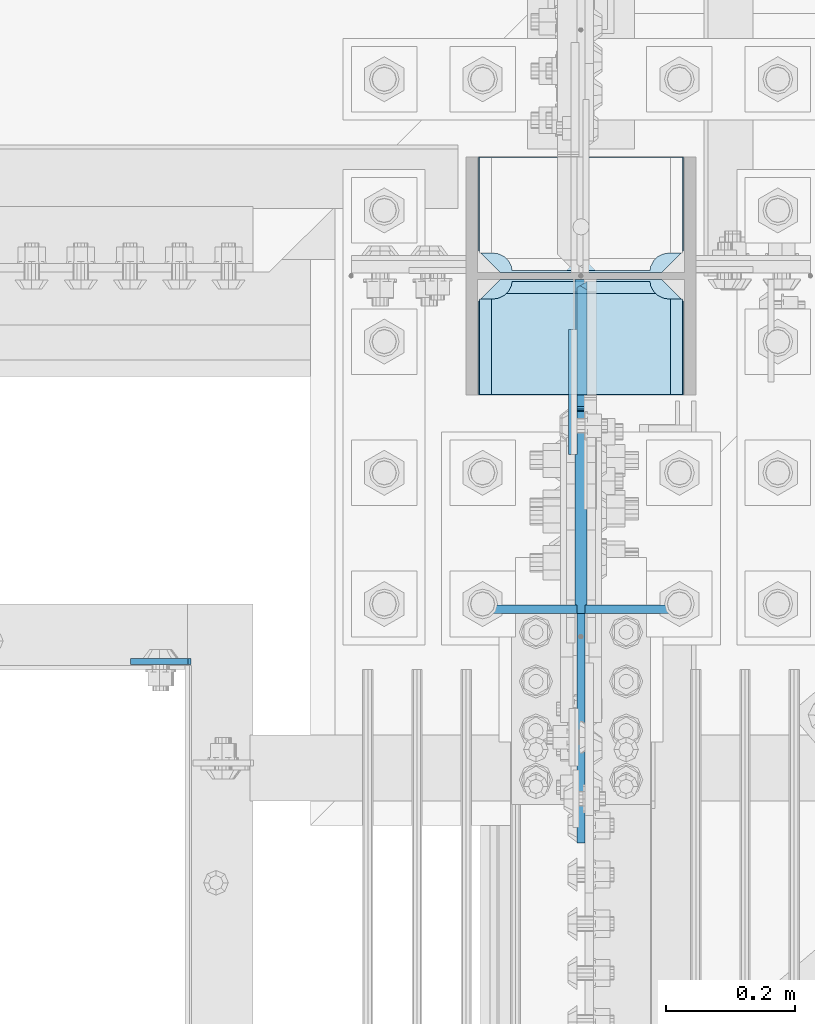
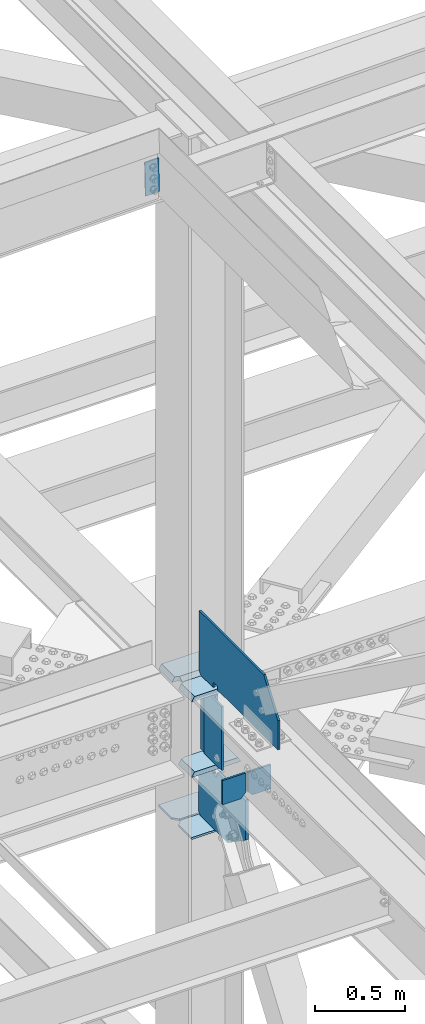
# One storey, part 3195 of 3843: 12 plates, 3 elements without a shape of their own.
"""IFC2X3 building model written with IfcOpenShell, lengths in millimetres."""

from ifc_helpers import new_model, si_unit, frame, origin_with_axes, place, context, subcontext, project, spatial, faceted_brep, material, type_object, element, aggregate, save


model = new_model("IFC2X3")

# Units and contexts
model_context = context("Model", 3, precision=1e-05, world=origin_with_axes())
body_context = subcontext(model_context, "Body", "Model", "MODEL_VIEW")
ifc_project = project(units=[si_unit("LENGTHUNIT", "METRE", prefix="MILLI"), si_unit("AREAUNIT", "SQUARE_METRE"), si_unit("VOLUMEUNIT", "CUBIC_METRE"), si_unit("MASSUNIT", "GRAM", prefix="KILO"), si_unit("TIMEUNIT", "SECOND"), si_unit("PLANEANGLEUNIT", "RADIAN"), si_unit("SOLIDANGLEUNIT", "STERADIAN"), si_unit("THERMODYNAMICTEMPERATUREUNIT", "DEGREE_CELSIUS"), si_unit("LUMINOUSINTENSITYUNIT", "LUMEN")], contexts=[model_context])

# Site, building, storey
site_placement = place(None, origin_with_axes())
site = spatial("IfcSite", under=ifc_project, at=site_placement, CompositionType="ELEMENT")
building_placement = place(site_placement, origin_with_axes())
building = spatial("IfcBuilding", under=site, at=building_placement, Name="Undefined", CompositionType="ELEMENT")
storey_placement = place(building_placement, origin_with_axes())
storey = spatial("IfcBuildingStorey", under=building, at=storey_placement, Name="Undefined", CompositionType="ELEMENT", Elevation=0.0)

# Assembly, plate
assembly_1_placement = place(storey_placement, origin_with_axes())
assembly_1 = element("IfcElementAssembly", 1, at=assembly_1_placement, inside=storey, Name="CHANNEL", AssemblyPlace="NOTDEFINED", PredefinedType="RIGID_FRAME")
ifc_material = material(Name="STEEL/A572-50")
plate_type_1 = type_object("IfcPlateType", PredefinedType="NOTDEFINED")
plate_1_placement = place(assembly_1_placement, frame((76404.0058949425, 25019.0000000661, 46534.1205115936), z_axis=(-0.999776270257024, 0.0, -0.0211520550054595), x_axis=(0.0211520550054438, 0.0, -0.999776270257025)))
plate_1 = element("IfcPlate", 2, at=plate_1_placement, type_object=plate_type_1, material=ifc_material, Name="PLATE", context=body_context, shape_type="Brep", body=[
    faceted_brep([(0.0, -4.76249999999709, 0.0), (0.0, -4.76249999999709, 88.9000015258789), (0.0, 4.76249999999709, 88.9000015258789), (0.0, 4.76249999999709, 0.0), (228.600006102781, -4.7625000004191, 88.9000015257589), (228.600006102781, 4.76249999954598, 88.9000015257443), (228.600006103079, -4.7625000004482, 7.27595761418343e-12), (228.600006103079, 4.76249999954598, -7.27595761418343e-12)], [[[0, 1, 2, 3]], [[1, 4, 5, 2]], [[4, 6, 7, 5]], [[6, 0, 3, 7]], [[5, 7, 3, 2]], [[6, 4, 1, 0]]]),
])
aggregate(assembly_1, [plate_1])

# Assembly, plates
assembly_2_placement = place(storey_placement, origin_with_axes())
assembly_2 = element("IfcElementAssembly", 3, at=assembly_2_placement, inside=storey, Name="BEAM", AssemblyPlace="NOTDEFINED", PredefinedType="RIGID_FRAME")
plate_type_2 = type_object("IfcPlateType", PredefinedType="NOTDEFINED")
plate_2_placement = place(assembly_2_placement, frame((77019.15, 25099.881157383, 42110.025), z_axis=(0.0, 0.0, -1.0), x_axis=(1.0, 0.0, 0.0)))
plate_2 = element("IfcPlate", 4, at=plate_2_placement, type_object=plate_type_2, material=ifc_material, Name="PLATE", context=body_context, shape_type="Brep", body=[
    faceted_brep([(0.0, -6.3499999046162, 0.0), (0.0, -6.35000000000582, 131.762499999997), (0.0, 6.35000000000582, 131.762499999997), (7.27595761418343e-12, 6.3499999046162, 0.0), (31.75, -6.35000000000582, 163.512499999997), (31.75, 6.35000000000582, 163.512499999997), (149.224999999991, -6.35000000000582, 163.512499999997), (149.224999999991, 6.35000000000582, 163.512499999997), (149.224999999991, -6.35000000000582, 0.0), (149.224999999991, 6.35000000000582, 0.0)], [[[0, 1, 2, 3]], [[1, 4, 5, 2]], [[4, 6, 7, 5]], [[6, 8, 9, 7]], [[8, 0, 3, 9]], [[5, 7, 9, 3, 2]], [[8, 6, 4, 1, 0]]]),
])
plate_3_placement = place(assembly_2_placement, frame((76857.225, 25099.881157383, 42110.025), z_axis=(0.0, 0.0, -1.0), x_axis=(1.0, 0.0, 0.0)))
plate_3 = element("IfcPlate", 5, at=plate_3_placement, type_object=plate_type_2, material=ifc_material, Name="PLATE", context=body_context, shape_type="Brep", body=[
    faceted_brep([(0.0, -6.3499999046162, 0.0), (0.0, -6.34999999999854, 163.512499999997), (0.0, 6.34999999999854, 163.512499999997), (7.27595761418343e-12, 6.3499999046162, 0.0), (117.474999999991, -6.34999999999854, 163.512499999997), (117.474999999991, 6.34999999999854, 163.512499999997), (149.224999999991, -6.34999999999854, 131.762499999997), (149.224999999991, 6.34999999999854, 131.762499999997), (149.224999999991, -6.35000000000582, 0.0), (149.224999999991, 6.35000000000582, 0.0)], [[[0, 1, 2, 3]], [[1, 4, 5, 2]], [[4, 6, 7, 5]], [[6, 8, 9, 7]], [[8, 0, 3, 9]], [[5, 7, 9, 3, 2]], [[8, 6, 4, 1, 0]]]),
])
aggregate(assembly_2, [plate_2, plate_3])

assembly_3_placement = place(storey_placement, origin_with_axes())
assembly_3 = element("IfcElementAssembly", 6, at=assembly_3_placement, inside=storey, Name="COLUMN", AssemblyPlace="NOTDEFINED", PredefinedType="RIGID_FRAME")
plate_type_3 = type_object("IfcPlateType", PredefinedType="NOTDEFINED")
plate_4_placement = place(assembly_3_placement, frame((77171.55, 25621.45625, 41513.3451620063), z_axis=(0.0, 1.0, 0.0), x_axis=(-1.0, 0.0, 0.0)))
plate_4 = element("IfcPlate", 7, at=plate_4_placement, type_object=plate_type_3, material=ifc_material, Name="CB_COL", context=body_context, shape_type="Brep", body=[
    faceted_brep([(0.0, -6.34999999999854, 33.3375015258789), (0.0, -6.34999999999854, 178.59375), (0.0, 6.34999999999854, 178.59375), (0.0, 6.34999999999854, 33.3375015258789), (317.499999999985, -6.34999999999854, 178.59375), (317.499999999985, 6.34999999999854, 178.59375), (317.499999999985, -6.34999999999854, 33.3375015258789), (317.499999999985, 6.34999999999854, 33.3375015258789), (284.162498474107, -6.34999999999854, 0.0), (284.162498474107, 6.34999999999854, 0.0), (33.3375015258789, -6.34999999999854, 0.0), (33.3375015258789, 6.34999999999854, 0.0)], [[[0, 1, 2, 3]], [[1, 4, 5, 2]], [[4, 6, 7, 5]], [[6, 8, 9, 7]], [[8, 10, 11, 9]], [[10, 0, 3, 11]], [[5, 7, 9, 11, 3, 2]], [[10, 8, 6, 4, 1, 0]]]),
])
plate_5_placement = place(assembly_3_placement, frame((77171.55, 25610.34375, 41513.3451620063), z_axis=(0.0, -1.0, 0.0), x_axis=(-1.0, 0.0, 0.0)))
plate_5 = element("IfcPlate", 8, at=plate_5_placement, type_object=plate_type_3, material=ifc_material, Name="CB_COL", context=body_context, shape_type="Brep", body=[
    faceted_brep([(0.0, -6.34999999999854, 33.3375015258789), (0.0, -6.34999999999854, 178.59375), (0.0, 6.34999999999854, 178.59375), (0.0, 6.34999999999854, 33.3375015258789), (317.499999999985, -6.34999999999854, 178.59375), (317.499999999985, 6.34999999999854, 178.59375), (317.499999999985, -6.34999999999854, 33.3375015258789), (317.499999999985, 6.34999999999854, 33.3375015258789), (284.162498474107, -6.34999999999854, 0.0), (284.162498474107, 6.34999999999854, 0.0), (33.3375015258789, -6.34999999999854, 0.0), (33.3375015258789, 6.34999999999854, 0.0)], [[[0, 1, 2, 3]], [[1, 4, 5, 2]], [[4, 6, 7, 5]], [[6, 8, 9, 7]], [[8, 10, 11, 9]], [[10, 0, 3, 11]], [[5, 7, 9, 11, 3, 2]], [[10, 8, 6, 4, 1, 0]]]),
])
plate_type_4 = type_object("IfcPlateType", PredefinedType="NOTDEFINED")
plate_6_placement = place(assembly_3_placement, frame((77012.8, 25093.531157383, 41925.875), z_axis=(0.0, 0.0, -1.0), x_axis=(0.0, 1.0, 0.0)))
plate_6 = element("IfcPlate", 9, at=plate_6_placement, type_object=plate_type_4, material=ifc_material, Name="CB", context=body_context, shape_type="Brep", body=[
    faceted_brep([(516.812592616985, -9.52499999999418, 387.129837993649), (516.812592616985, 9.52499999999418, 387.129837993649), (497.762592616986, 9.52499999999418, 406.179837993652), (497.762592616986, -9.52499999999418, 406.179837993652), (0.0, -9.52499999999418, 270.061563222225), (195.385083612466, -9.52499999999418, 406.179837993652), (195.385083612466, 9.52499999999418, 406.179837993652), (0.0, 9.52499999999418, 270.061563222225), (0.0, -9.52500000000146, 0.0), (0.0, 9.52500000000146, 0.0), (312.818842616984, 9.52499999999418, 0.0), (312.818842616984, -9.52499999999418, 0.0), (312.818842616984, 9.52499999999418, 25.4000001907334), (312.818842616984, -9.52499999999418, 25.4000001907334), (313.785572539571, 9.52499999999418, 30.2600797087798), (313.785572539571, -9.52499999999418, 30.2600797087798), (316.538586440049, 9.52499999999418, 34.3802561769335), (316.538586440049, -9.52499999999418, 34.3802561769335), (320.658762908202, 9.52499999999418, 37.1332700774074), (320.658762908202, -9.52499999999418, 37.1332700774074), (325.518842426249, 9.52499999999418, 38.0999999999985), (325.518842426249, -9.52499999999418, 38.0999999999985), (350.918842807718, 9.52499999999418, 38.0999999999985), (350.918842807718, -9.52499999999418, 38.0999999999985), (355.778922325764, 9.52499999999418, 37.1332700774074), (355.778922325764, -9.52499999999418, 37.1332700774074), (359.899098793918, 9.52499999999418, 34.3802561769335), (359.899098793918, -9.52499999999418, 34.3802561769335), (362.652112694395, 9.52499999999418, 30.2600797087798), (362.652112694395, -9.52499999999418, 30.2600797087798), (363.618842616983, 9.52499999999418, 25.4000001907334), (363.618842616983, -9.52499999999418, 25.4000001907334), (363.618842616983, 9.52499999999418, 0.0), (363.618842616983, -9.52499999999418, 0.0), (497.762593379925, 9.52499999999418, 0.0), (497.762593379925, -9.52499999999418, 0.0), (516.812592616985, -9.52499999999418, 19.0499992370605), (516.812592616985, 9.52499999999418, 19.0499992370605)], [[[0, 1, 2, 3]], [[4, 5, 6, 7]], [[8, 4, 7, 9]], [[8, 9, 10, 11]], [[11, 10, 12, 13]], [[13, 12, 14, 15]], [[15, 14, 16, 17]], [[17, 16, 18, 19]], [[19, 18, 20, 21]], [[21, 20, 22, 23]], [[23, 22, 24, 25]], [[25, 24, 26, 27]], [[27, 26, 28, 29]], [[29, 28, 30, 31]], [[31, 30, 32, 33]], [[34, 35, 33, 32]], [[36, 35, 34, 37]], [[5, 4, 8, 11, 13, 15, 17, 19, 21, 23, 25, 27, 29, 31, 33, 35, 36, 0, 3]], [[6, 5, 3, 2]], [[37, 34, 32, 30, 28, 26, 24, 22, 20, 18, 16, 14, 12, 10, 9, 7, 6, 2, 1]], [[36, 37, 1, 0]]]),
])
plate_type_5 = type_object("IfcPlateType", PredefinedType="NOTDEFINED")
plate_7_placement = place(assembly_3_placement, frame((77012.7999999709, 25610.3437500067, 42468.7999999896), z_axis=(0.0, -1.0, 0.0), x_axis=(0.0, 0.0, 1.0)))
plate_7 = element("IfcPlate", 10, at=plate_7_placement, type_object=plate_type_5, material=ifc_material, Name="PLATE", context=body_context, shape_type="Brep", body=[
    faceted_brep([(12.6999999999971, -6.35000000000582, 203.993750006706), (12.6999999999971, 6.35000000000582, 203.993750006706), (25.4000002011162, 6.35000000000582, 203.993750006706), (25.4000002011162, -6.35000000000582, 203.993750006706), (30.2600797191626, 6.35000000000582, 203.027020084119), (30.2600797191626, -6.35000000000582, 203.027020084119), (34.3802561873163, 6.35000000000582, 200.274006183641), (34.3802561873163, -6.35000000000582, 200.274006183641), (37.1332700877902, 6.35000000000582, 196.153829715488), (37.1332700877902, -6.35000000000582, 196.153829715488), (25.4000002011162, -6.35000000000582, 153.193750006707), (25.4000002011162, 6.35000000000582, 153.193750006707), (0.0, 6.35000000000582, 153.193750006707), (0.0, -6.35000000000582, 153.193750006707), (30.2600797191626, -6.35000000000582, 154.160479929295), (30.2600797191626, 6.35000000000582, 154.160479929295), (34.3802561873163, -6.35000000000582, 156.913493829772), (34.3802561873163, 6.35000000000582, 156.913493829772), (37.1332700877902, -6.35000000000582, 161.033670297926), (37.1332700877902, 6.35000000000582, 161.033670297926), (38.1000000103813, -6.35000000000582, 165.893749815972), (38.1000000103813, 6.35000000000582, 165.893749815972), (38.1000000103813, -6.35000000000582, 191.293750197441), (38.1000000103813, 6.35000000000582, 191.293750197441), (211.188134383417, -6.35000000000582, 872.381515932011), (211.188134383417, 6.35000000000582, 872.381515932011), (12.6999999999971, 6.35000000000582, 872.381515932011), (12.6999999999971, -6.35000000000582, 872.381515932011), (426.72660716984, -6.35000000000582, 715.308103958829), (426.72660716984, 6.35000000000582, 715.308103958829), (426.72660716984, -6.35000000000582, 0.0), (426.72660716984, 6.35000000000582, 0.0), (19.0499992370605, -6.34999999999854, 0.0), (19.0499992370605, 6.34999999999854, 0.0), (0.0, -6.34999999999854, 19.0499992370605), (0.0, 6.34999999999854, 19.0499992370605)], [[[0, 1, 2, 3]], [[3, 2, 4, 5]], [[5, 4, 6, 7]], [[7, 6, 8, 9]], [[10, 11, 12, 13]], [[14, 15, 11, 10]], [[16, 17, 15, 14]], [[18, 19, 17, 16]], [[20, 21, 19, 18]], [[22, 23, 21, 20]], [[9, 8, 23, 22]], [[24, 25, 26, 27]], [[24, 28, 29, 25]], [[28, 30, 31, 29]], [[31, 30, 32, 33]], [[32, 34, 35, 33]], [[35, 34, 13, 12]], [[6, 4, 2, 1, 26, 25, 29, 31, 33, 35, 12, 11, 15, 17, 19, 21, 23, 8]], [[27, 26, 1, 0]], [[18, 16, 14, 10, 13, 34, 32, 30, 28, 24, 27, 0, 3, 5, 7, 9, 22, 20]]]),
])
plate_type_6 = type_object("IfcPlateType", PredefinedType="NOTDEFINED")
plate_8_placement = place(assembly_3_placement, frame((76852.4625, 25621.45625, 42452.925), z_axis=(1.0, 0.0, 0.0), x_axis=(0.0, 1.0, 0.0)))
plate_8 = element("IfcPlate", 11, at=plate_8_placement, type_object=plate_type_6, material=ifc_material, Name="PLATE", context=body_context, shape_type="Brep", body=[
    faceted_brep([(17.7290728964945, 9.33436282556067, 272.460526505907), (21.5053709990898, 15.875, 276.236824608495), (21.5053709990898, 15.875, 44.4381753915077), (17.7290728964945, 9.33436282556067, 48.2144734940957), (9.32072521071677, -5.22909322453052, 52.4987406282016), (3.174499952318, -15.875, 53.472207075858), (3.174499952318, -15.875, 267.202792924145), (9.32072521071314, -5.22909322453052, 268.176259371801), (30.1625003814697, 15.875, 299.168629000924), (30.1625003814697, -15.875, 317.499500047692), (177.799999999999, -15.875, 317.499500047692), (177.799999999999, 15.875, 299.168629000924), (177.799999999999, 15.875, 21.5053709990898), (177.799999999999, -15.875, 3.17449995232164), (30.1625003814697, -15.875, 3.17449995232164), (30.1625003814697, 15.875, 21.5053709990898), (9.32072521071314, -15.875, 268.176259371801), (17.7290728964945, -15.875, 272.460526505907), (24.401975401448, -15.875, 279.133429010864), (24.401975401448, 15.875, 279.133429010864), (28.6862425355503, -15.875, 287.541776696642), (28.6862425355503, 15.875, 287.541776696642), (30.1625003814697, -15.875, 296.862501907352), (30.1625003814697, 15.875, 296.862501907352), (30.1625003814697, -15.875, 23.8124980926514), (30.1625003814697, 15.875, 23.8124980926514), (28.6862425355503, -15.875, 33.1332233033609), (28.6862425355503, 15.875, 33.1332233033609), (24.401975401448, -15.875, 41.5415709891386), (24.401975401448, 15.875, 41.5415709891386), (17.7290728964945, -15.875, 48.2144734940957), (9.32072521071677, -15.875, 52.4987406282016)], [[[0, 1, 2, 3, 4, 5, 6, 7]], [[8, 9, 10, 11]], [[12, 13, 14, 15]], [[16, 7, 6]], [[16, 17, 0, 7]], [[17, 18, 19, 1, 0]], [[18, 20, 21, 19]], [[20, 22, 23, 21]], [[23, 22, 9, 8]], [[13, 12, 11, 10]], [[24, 25, 15, 14]], [[24, 26, 27, 25]], [[26, 28, 29, 27]], [[29, 28, 30, 3, 2]], [[30, 31, 4, 3]], [[31, 5, 4]], [[19, 21, 23, 8, 11, 12, 15, 25, 27, 29, 2, 1]], [[31, 30, 28, 26, 24, 14, 13, 10, 9, 22, 20, 18, 17, 16, 6, 5]]]),
])
plate_9_placement = place(assembly_3_placement, frame((76852.4625, 25432.54375, 41941.75), z_axis=(1.0, 0.0, 0.0), x_axis=(0.0, 1.0, 0.0)))
plate_9 = element("IfcPlate", 12, at=plate_9_placement, type_object=plate_type_6, material=ifc_material, Name="PLATE", context=body_context, shape_type="Brep", body=[
    faceted_brep([(160.070927103505, 9.33329077896633, 48.2144734940957), (156.294129000915, 15.875, 44.437675391513), (156.294129000915, 15.875, 276.23732460849), (160.070927103505, 9.33329077896633, 272.460526505907), (168.479274789282, -5.23062396988826, 268.176259371801), (174.625000047687, -15.875, 267.202872116366), (174.625000047687, -15.875, 53.4721278836369), (168.479274789282, -5.23062396988826, 52.4987406282016), (147.63749961853, 15.875, 21.5053709990898), (147.63749961853, -15.875, 3.17449995232164), (0.0, -15.875, 3.17449995232164), (0.0, 15.875, 21.5053709990898), (0.0, 15.875, 299.168629000924), (0.0, -15.875, 317.499500047692), (147.63749961853, -15.875, 317.499500047692), (147.63749961853, 15.875, 299.168629000924), (147.63749961853, -15.875, 296.862501907352), (147.63749961853, 15.875, 296.862501907352), (149.113757464445, -15.875, 287.541776696642), (149.113757464445, 15.875, 287.541776696642), (153.398024598548, -15.875, 279.133429010864), (153.398024598548, 15.875, 279.133429010864), (160.070927103505, -15.875, 272.460526505907), (168.479274789282, -15.875, 268.176259371801), (168.479274789282, -15.875, 52.4987406282016), (160.070927103505, -15.875, 48.2144734940957), (153.398024598548, -15.875, 41.5415709891386), (153.398024598548, 15.875, 41.5415709891386), (149.113757464449, -15.875, 33.1332233033609), (149.113757464449, 15.875, 33.1332233033609), (147.63749961853, -15.875, 23.8124980926514), (147.63749961853, 15.875, 23.8124980926514)], [[[0, 1, 2, 3, 4, 5, 6, 7]], [[8, 9, 10, 11]], [[12, 13, 14, 15]], [[13, 12, 11, 10]], [[16, 17, 15, 14]], [[16, 18, 19, 17]], [[18, 20, 21, 19]], [[21, 20, 22, 3, 2]], [[22, 23, 4, 3]], [[23, 5, 4]], [[24, 7, 6]], [[24, 25, 0, 7]], [[25, 26, 27, 1, 0]], [[26, 28, 29, 27]], [[28, 30, 31, 29]], [[31, 30, 9, 8]], [[27, 29, 31, 8, 11, 12, 15, 17, 19, 21, 2, 1]], [[9, 30, 28, 26, 25, 24, 6, 5, 23, 22, 20, 18, 16, 14, 13, 10]]]),
])
plate_10_placement = place(assembly_3_placement, frame((76852.4625, 25432.54375, 42452.925), z_axis=(1.0, 0.0, 0.0), x_axis=(0.0, 1.0, 0.0)))
plate_10 = element("IfcPlate", 13, at=plate_10_placement, type_object=plate_type_6, material=ifc_material, Name="PLATE", context=body_context, shape_type="Brep", body=[
    faceted_brep([(160.070927103505, 9.33349681380787, 48.2144734940957), (156.294129000915, 15.875, 44.437675391513), (156.294129000915, 15.875, 276.23732460849), (160.070927103505, 9.33349681380787, 272.460526505907), (168.479274789282, -5.2299592362906, 268.176259371801), (174.625000047687, -15.875, 267.202872116366), (174.625000047687, -15.875, 53.4721278836369), (168.479274789282, -5.2299592362906, 52.4987406282016), (147.63749961853, 15.875, 21.5053709990898), (147.63749961853, -15.875, 3.17449995232164), (0.0, -15.875, 3.17449995232164), (0.0, 15.875, 21.5053709990898), (0.0, 15.875, 299.168629000924), (0.0, -15.875, 317.499500047692), (147.63749961853, -15.875, 317.499500047692), (147.63749961853, 15.875, 299.168629000924), (147.63749961853, -15.875, 296.862501907352), (147.63749961853, 15.875, 296.862501907352), (149.113757464445, -15.875, 287.541776696642), (149.113757464445, 15.875, 287.541776696642), (153.398024598548, -15.875, 279.133429010864), (153.398024598548, 15.875, 279.133429010864), (160.070927103505, -15.875, 272.460526505907), (168.479274789282, -15.875, 268.176259371801), (168.479274789282, -15.875, 52.4987406282016), (160.070927103505, -15.875, 48.2144734940957), (153.398024598548, -15.875, 41.5415709891386), (153.398024598548, 15.875, 41.5415709891386), (149.113757464449, -15.875, 33.1332233033609), (149.113757464449, 15.875, 33.1332233033609), (147.63749961853, -15.875, 23.8124980926514), (147.63749961853, 15.875, 23.8124980926514)], [[[0, 1, 2, 3, 4, 5, 6, 7]], [[8, 9, 10, 11]], [[12, 13, 14, 15]], [[13, 12, 11, 10]], [[16, 17, 15, 14]], [[16, 18, 19, 17]], [[18, 20, 21, 19]], [[21, 20, 22, 3, 2]], [[22, 23, 4, 3]], [[23, 5, 4]], [[24, 7, 6]], [[24, 25, 0, 7]], [[25, 26, 27, 1, 0]], [[26, 28, 29, 27]], [[28, 30, 31, 29]], [[31, 30, 9, 8]], [[27, 29, 31, 8, 11, 12, 15, 17, 19, 21, 2, 1]], [[9, 30, 28, 26, 25, 24, 6, 5, 23, 22, 20, 18, 16, 14, 13, 10]]]),
])
plate_type_7 = type_object("IfcPlateType", PredefinedType="NOTDEFINED")
plate_11_placement = place(assembly_3_placement, frame((77014.3875, 25610.3437500117, 41976.6750000008), z_axis=(0.0, -0.707106781186682, 0.707106781186413), x_axis=(0.0, -0.707106781186548, -0.707106781186548)))
plate_11 = element("IfcPlate", 14, at=plate_11_placement, type_object=plate_type_7, material=ifc_material, Name="PLATE", context=body_context, shape_type="Brep", body=[
    faceted_brep([(-312.063900187669, 7.9375, 316.55402818077), (4.49012799373304, 7.9375, 0.0), (13.4703841824085, -3.06102271161217, -3.63797880709171e-12), (13.4703841830633, -7.9375, 3.98162703275011), (-308.082273151626, -7.9375, 325.53428436687), (-312.06390018768, -3.06102270777046, 325.534284366877), (22.4506403697887, 7.9375, -1.81898940354586e-11), (137.510171880771, 7.93750000091677, 115.059531510957), (131.029230271015, -7.9375, 121.540473120702), (-190.523427063413, -7.9375, 443.093130455098), (-197.004368674482, 7.9375, 449.574072066178), (-312.063900187676, 7.9375, 334.514540552969), (62.3005266916225, 7.9375, 190.269176711488), (62.3005266916225, -7.9375, 190.269176711488), (-171.186132170253, 7.9375, 423.755835579228), (-171.186132170253, -7.9375, 423.755835579228)], [[[0, 1, 2, 3, 4, 5]], [[6, 7, 8, 3, 2]], [[9, 10, 11, 5, 4]], [[6, 2, 1]], [[12, 13, 8, 7]], [[14, 15, 13, 12]], [[8, 13, 15, 9, 4, 3]], [[11, 0, 5]], [[14, 12, 7, 6, 1, 0, 11, 10]], [[15, 14, 10, 9]]]),
])
plate_type_8 = type_object("IfcPlateType", PredefinedType="NOTDEFINED")
plate_12_placement = place(assembly_3_placement, frame((77000.1, 25339.6750004233, 42413.2375), z_axis=(0.0, 0.0, -1.0), x_axis=(0.0, 1.0, 0.0)))
plate_12 = element("IfcPlate", 15, at=plate_12_placement, type_object=plate_type_8, material=ifc_material, Name="PLATE", context=body_context, shape_type="Brep", body=[
    faceted_brep([(0.0, -6.3499999046162, 0.0), (0.0, -6.35000000000582, 431.800000000003), (0.0, 6.35000000000582, 431.800000000003), (7.27595761418343e-12, 6.3499999046162, 0.0), (193.674999999996, -6.35000000000582, 431.800000000003), (193.674999999996, 6.35000000000582, 431.800000000003), (193.674999999996, -6.35000000000582, 0.0), (193.674999999996, 6.35000000000582, 0.0)], [[[0, 1, 2, 3]], [[1, 4, 5, 2]], [[4, 6, 7, 5]], [[6, 0, 3, 7]], [[5, 7, 3, 2]], [[6, 4, 1, 0]]]),
])
aggregate(assembly_3, [plate_4, plate_5, plate_6, plate_7, plate_8, plate_9, plate_10, plate_12, plate_11])

save(model, "model.ifc")
